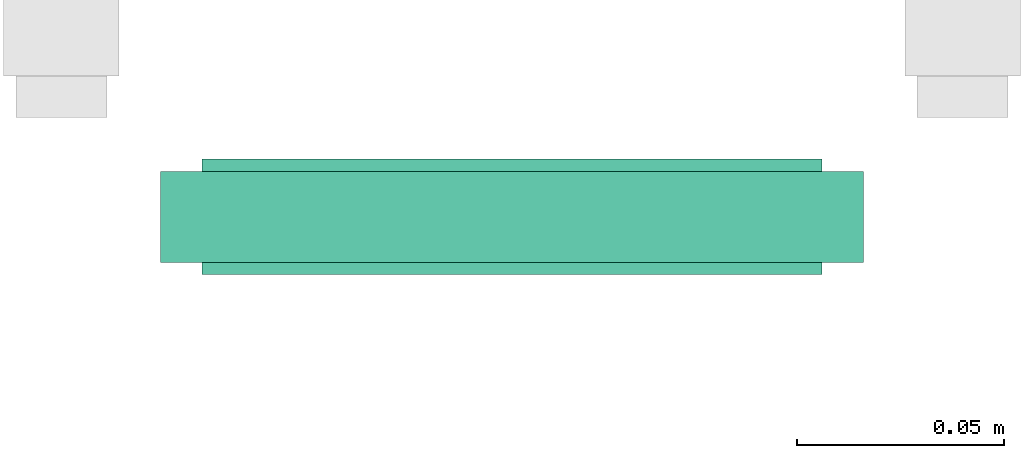
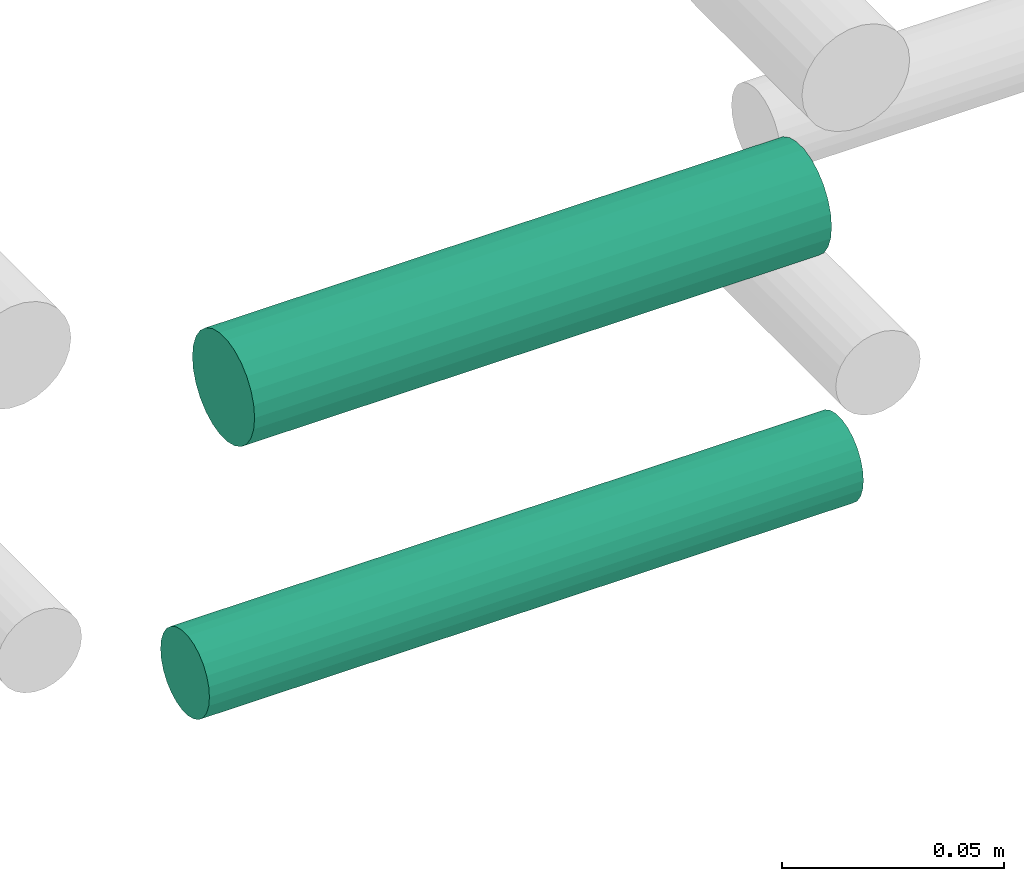
# One storey, part 202 of 331: 2 flow segments.
"""IFC2X3 building model written with IfcOpenShell, lengths in millimetres."""

from ifc_helpers import new_model, entity, si_unit, converted_unit, derived_unit, direction, frame, origin, origin_2d_with_axis, place, context, subcontext, project, spatial, circle, extrude, type_object, element, save


model = new_model("IFC2X3")

# Units and contexts
model_context = context("Model", 3, precision=0.01, world=origin(), true_north=direction((6.12303176911189e-17, 1.0)))
body_context = subcontext(model_context, "Body", "Model", "MODEL_VIEW")
ifc_project = project(units=[si_unit("LENGTHUNIT", "METRE", prefix="MILLI"), si_unit("AREAUNIT", "SQUARE_METRE"), si_unit("VOLUMEUNIT", "CUBIC_METRE"), converted_unit("PLANEANGLEUNIT", "DEGREE", entity("IfcRatioMeasure", 0.0174532925199433), si_unit("PLANEANGLEUNIT", "RADIAN"), dimensions=[0, 0, 0, 0, 0, 0, 0]), si_unit("MASSUNIT", "GRAM", prefix="KILO"), derived_unit("MASSDENSITYUNIT", [(si_unit("MASSUNIT", "GRAM", prefix="KILO"), 1), (si_unit("LENGTHUNIT", "METRE"), -3)]), derived_unit("MOMENTOFINERTIAUNIT", [(si_unit("LENGTHUNIT", "METRE"), 4)]), si_unit("TIMEUNIT", "SECOND"), si_unit("FREQUENCYUNIT", "HERTZ"), si_unit("THERMODYNAMICTEMPERATUREUNIT", "DEGREE_CELSIUS"), derived_unit("THERMALTRANSMITTANCEUNIT", [(si_unit("MASSUNIT", "GRAM", prefix="KILO"), 1), (si_unit("THERMODYNAMICTEMPERATUREUNIT", "KELVIN"), -1), (si_unit("TIMEUNIT", "SECOND"), -3)]), derived_unit("VOLUMETRICFLOWRATEUNIT", [(si_unit("LENGTHUNIT", "METRE"), 3), (si_unit("TIMEUNIT", "SECOND"), -1)]), derived_unit("MASSFLOWRATEUNIT", [(si_unit("MASSUNIT", "GRAM", prefix="KILO"), 1), (si_unit("TIMEUNIT", "SECOND"), -1)]), derived_unit("ROTATIONALFREQUENCYUNIT", [(si_unit("TIMEUNIT", "SECOND"), -1)]), si_unit("ELECTRICCURRENTUNIT", "AMPERE"), si_unit("ELECTRICVOLTAGEUNIT", "VOLT"), si_unit("POWERUNIT", "WATT"), si_unit("FORCEUNIT", "NEWTON", prefix="KILO"), si_unit("ILLUMINANCEUNIT", "LUX"), si_unit("LUMINOUSFLUXUNIT", "LUMEN"), si_unit("LUMINOUSINTENSITYUNIT", "CANDELA"), derived_unit("USERDEFINED", [(si_unit("MASSUNIT", "GRAM", prefix="KILO"), -1), (si_unit("LENGTHUNIT", "METRE"), -2), (si_unit("TIMEUNIT", "SECOND"), 3), (si_unit("LUMINOUSFLUXUNIT", "LUMEN"), 1)]), derived_unit("LINEARVELOCITYUNIT", [(si_unit("LENGTHUNIT", "METRE"), 1), (si_unit("TIMEUNIT", "SECOND"), -1)]), si_unit("PRESSUREUNIT", "PASCAL"), derived_unit("USERDEFINED", [(si_unit("LENGTHUNIT", "METRE"), -2), (si_unit("MASSUNIT", "GRAM", prefix="KILO"), 1), (si_unit("TIMEUNIT", "SECOND"), -2)]), derived_unit("LINEARFORCEUNIT", [(si_unit("MASSUNIT", "GRAM", prefix="KILO"), 1), (si_unit("LENGTHUNIT", "METRE"), 1), (si_unit("TIMEUNIT", "SECOND"), -2), (si_unit("LENGTHUNIT", "METRE"), -1)]), derived_unit("PLANARFORCEUNIT", [(si_unit("MASSUNIT", "GRAM", prefix="KILO"), 1), (si_unit("LENGTHUNIT", "METRE"), 1), (si_unit("TIMEUNIT", "SECOND"), -2), (si_unit("LENGTHUNIT", "METRE"), -2)])], contexts=[model_context])

# Site, building, storey
site_placement = place(None, frame((0.0, -0.00077364408347762, 0.0)))
site = spatial("IfcSite", under=ifc_project, at=site_placement, CompositionType="ELEMENT")
building_placement = place(site_placement, origin())
building = spatial("IfcBuilding", under=site, at=building_placement, CompositionType="ELEMENT")
storey_placement = place(building_placement, origin())
storey = spatial("IfcBuildingStorey", under=building, at=storey_placement, CompositionType="ELEMENT", Elevation=0.0)

# Flow segments
pipe_segment_type = type_object("IfcPipeSegmentType", PredefinedType="NOTDEFINED")
flow_segment_1_placement = place(building_placement, frame((54446.2595287085, 8059.40478879924, 2759.40472776401)))
element("IfcFlowSegment", 1, at=flow_segment_1_placement, inside=storey, type_object=pipe_segment_type, context=body_context, shape_type="SweptSolid", body=[
    extrude(circle(Radius=14.0, at=origin_2d_with_axis()), frame((0.0, 15.5952722359149, 15.595272235916), z_axis=(1.0, 0.0, 0.0), x_axis=(0.0, -1.0, 0.0)), (0.0, 0.0, 1.0), 149.945890422649),
])
flow_segment_2_placement = place(building_placement, frame((54436.2595287086, 8062.40478879923, 2687.40472776402)))
element("IfcFlowSegment", 2, at=flow_segment_2_placement, inside=storey, type_object=pipe_segment_type, context=body_context, shape_type="SweptSolid", body=[
    extrude(circle(Radius=11.0, at=origin_2d_with_axis()), frame((0.0, 12.5952722359156, 12.5952722359161), z_axis=(1.0, 0.0, 0.0), x_axis=(0.0, -1.0, 0.0)), (0.0, 0.0, 1.0), 169.945890422601),
])

save(model, "model.ifc")
